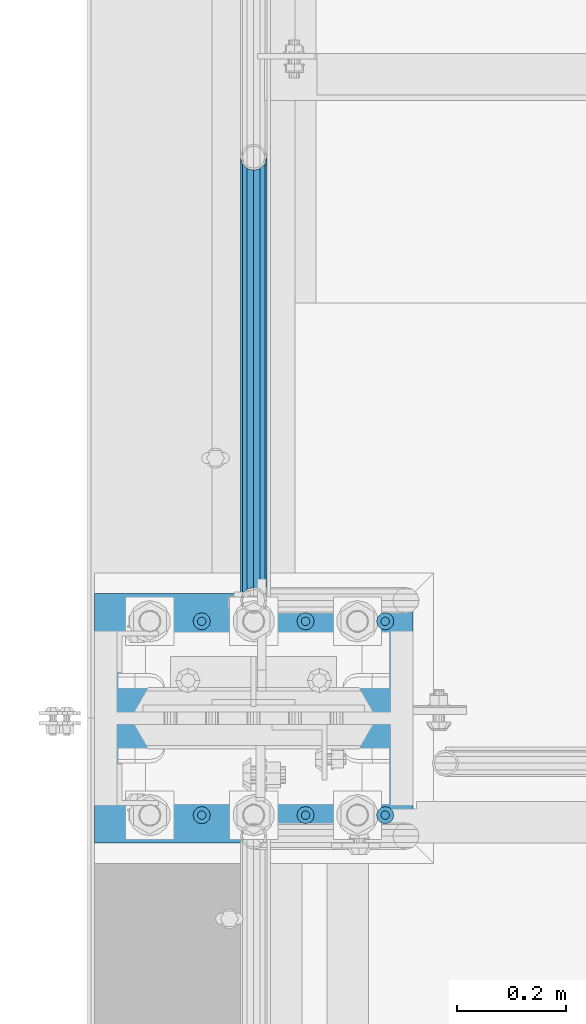
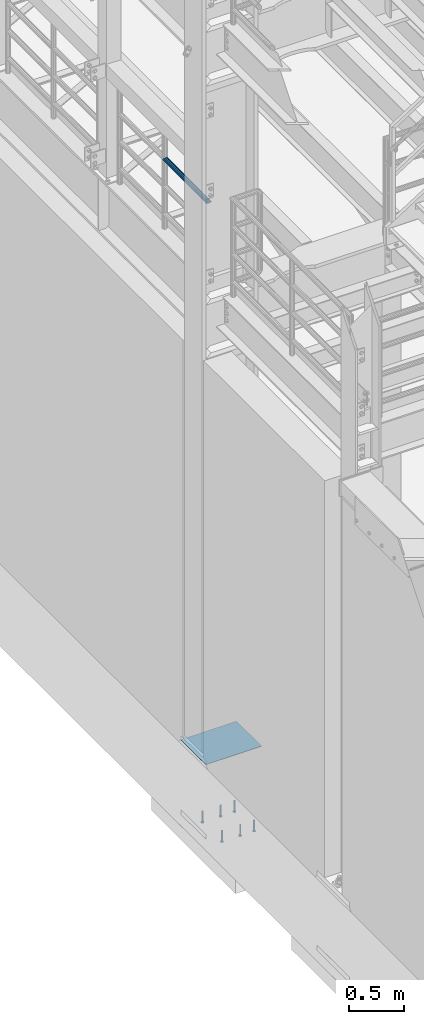
# One storey, part 1163 of 1876: 8 beams, 2 elements without a shape of their own.
"""IFC2X3 building model written with IfcOpenShell, lengths in millimetres."""

import ifcopenshell
import ifcopenshell.guid

model = None  # the IFC model being written
_history = None  # IfcOwnerHistory: only IFC2X3 demands one
_inside = {}  # id of a spatial element -> (the spatial element, [elements in it])
_under = {}  # id of a project, library or spatial element -> (it, [spatial elements below it])
_declared = {}  # id of a project -> (the project, [libraries it declares])
_typed = {}  # id of a type object -> (the type object, [elements of that type])
_made_of = {}  # id of a material, layer set ... -> (it, [elements and type objects made of it])


def new_model(schema):
    """Start an empty IFC model of exactly this schema.

    Asked for "IFC4X3", IfcOpenShell would pick the latest addendum, in which some entities
    have other attributes; the version numbers below select the first issue.
    IFC2X3 requires an IfcOwnerHistory on every rooted entity: one is made here for all.
    """
    global model, _history
    if schema == "IFC4X3":
        model = ifcopenshell.file(schema_version=(4, 3, 0, 0))
    else:
        model = ifcopenshell.file(schema=schema)
    _inside.clear()
    _under.clear()
    _declared.clear()
    _typed.clear()
    _made_of.clear()
    _history = None
    if model.schema == "IFC2X3":
        org = make("IfcOrganization", Name="unknown")
        user = make(
            "IfcPersonAndOrganization",
            ThePerson=make("IfcPerson", FamilyName="unknown"),
            TheOrganization=org,
        )
        app = make(
            "IfcApplication",
            ApplicationDeveloper=org,
            Version="unknown",
            ApplicationFullName="unknown",
            ApplicationIdentifier="unknown",
        )
        _history = make(
            "IfcOwnerHistory",
            OwningUser=user,
            OwningApplication=app,
            ChangeAction="ADDED",
            CreationDate=0,
        )
    return model


def make(cls, **values):
    """One entity of the class cls with the attributes given. An attribute that is None is left unset."""
    return model.create_entity(
        cls, **{name: value for name, value in values.items() if value is not None}
    )


def rooted(cls, **values):
    """An entity with a GlobalId (a new one), such as an element, a storey or a relation."""
    return make(cls, GlobalId=ifcopenshell.guid.new(), OwnerHistory=_history, **values)


def si_unit(unit_type, name, prefix=None):
    """IfcSIUnit, for example si_unit("LENGTHUNIT", "METRE", prefix="MILLI")."""
    return make("IfcSIUnit", UnitType=unit_type, Prefix=prefix, Name=name)


def assignment(units):
    """IfcUnitAssignment: the units of a project."""
    return None if units is None else make("IfcUnitAssignment", Units=units)


def point(xyz):
    """IfcCartesianPoint."""
    return None if xyz is None else make("IfcCartesianPoint", Coordinates=xyz)


def direction(xyz):
    """IfcDirection."""
    return None if xyz is None else make("IfcDirection", DirectionRatios=xyz)


def frame(location, z_axis=None, x_axis=None):
    """IfcAxis2Placement3D, a coordinate frame: its origin and axes. An axis left out is left unset."""
    return make(
        "IfcAxis2Placement3D",
        Location=point(location),
        Axis=direction(z_axis),
        RefDirection=direction(x_axis),
    )


def origin_with_axes():
    """The frame at (0, 0, 0) with the z axis (0, 0, 1) and the x axis (1, 0, 0) written out."""
    return frame((0.0, 0.0, 0.0), z_axis=(0.0, 0.0, 1.0), x_axis=(1.0, 0.0, 0.0))


def place(relative_to, where):
    """IfcLocalPlacement: puts the frame where relative to a parent placement (None: the world)."""
    return make(
        "IfcLocalPlacement", PlacementRelTo=relative_to, RelativePlacement=where
    )


def context(
    kind, dimensions, precision=None, world=None, true_north=None, identifier=None
):
    """IfcGeometricRepresentationContext, for example the 3D "Model" context."""
    return make(
        "IfcGeometricRepresentationContext",
        ContextIdentifier=identifier,
        ContextType=kind,
        CoordinateSpaceDimension=dimensions,
        Precision=precision,
        WorldCoordinateSystem=world,
        TrueNorth=true_north,
    )


def subcontext(parent, identifier, kind, view, scale=None):
    """IfcGeometricRepresentationSubContext, for example "Body" below "Model"."""
    return make(
        "IfcGeometricRepresentationSubContext",
        ContextIdentifier=identifier,
        ContextType=kind,
        ParentContext=parent,
        TargetScale=scale,
        TargetView=view,
    )


def project(units=None, contexts=None):
    """IfcProject with its units and contexts."""
    return rooted(
        "IfcProject",
        Name="project",
        RepresentationContexts=contexts,
        UnitsInContext=assignment(units),
    )


def spatial(cls, under=None, at=None, **own):
    """A site, building, storey or space (cls), placed at a placement, below another one or the project."""
    s = rooted(cls, ObjectPlacement=at, **own)
    if under is not None:
        _under.setdefault(under.id(), (under, []))[1].append(s)
    return s


def faces_of(points, faces, orient=None, outer=None):
    """IfcFace entities. A face is a list of loops; a loop is a list of indices into points, from 0.

    orient and outer hold one flag for each loop. By default every Orientation is true, the
    first loop of a face is its IfcFaceOuterBound and the others are IfcFaceBound.
    """
    made = []
    for i, loops in enumerate(faces):
        bounds = []
        for j, loop in enumerate(loops):
            is_outer = j == 0 if outer is None else outer[i][j]
            bounds.append(
                make(
                    "IfcFaceOuterBound" if is_outer else "IfcFaceBound",
                    Bound=make("IfcPolyLoop", Polygon=[points[k] for k in loop]),
                    Orientation=True if orient is None else orient[i][j],
                )
            )
        made.append(make("IfcFace", Bounds=bounds))
    return made


def faceted_brep(points, faces, orient=None, outer=None, voids=None):
    """IfcFacetedBrep: a solid bounded by flat faces; with voids (closed shells), ...WithVoids."""
    shared = [point(p) for p in points]
    hull = make("IfcClosedShell", CfsFaces=faces_of(shared, faces, orient, outer))
    if voids is None:
        return make("IfcFacetedBrep", Outer=hull)
    return make(
        "IfcFacetedBrepWithVoids",
        Outer=hull,
        Voids=[
            make(cls, CfsFaces=faces_of(shared, fs, o, b)) for cls, fs, o, b in voids
        ],
    )


def shape(context_of_items, identifier, shape_type, items):
    """IfcShapeRepresentation: the items that make up one representation, for example the "Body"."""
    return make(
        "IfcShapeRepresentation",
        ContextOfItems=context_of_items,
        RepresentationIdentifier=identifier,
        RepresentationType=shape_type,
        Items=items,
    )


def material(Name=None, Category=None):
    """IfcMaterial."""
    return make("IfcMaterial", Name=Name, Category=Category)


def made_of(thing, what):
    """Note that an element or type object is made of a material, layer set ...; save() writes the relation."""
    if what is not None:
        _made_of.setdefault(what.id(), (what, []))[1].append(thing)
    return thing


def type_object(cls, material=None, **own):
    """A type object (cls), such as IfcWallType, which elements share."""
    return made_of(rooted(cls, **own), material)


def element(
    cls,
    number,
    at=None,
    inside=None,
    cuts=None,
    type_object=None,
    material=None,
    context=None,
    identifier="Body",
    shape_type=None,
    held_by="IfcProductDefinitionShape",
    body=None,
    shapes=None,
    **own,
):
    """One element of the class cls, such as IfcWall. Its Tag is "e" and its number.

    at: its placement. inside: the storey or other place that contains it. cuts: it is an
    opening in that element (IfcRelVoidsElement). A single representation is given by context,
    identifier, shape_type and body (its items); several are given by shapes. held_by: the class
    of the entity that holds the representations. save() writes the other relations.
    """
    e = rooted(cls, Tag="e%d" % number, ObjectPlacement=at, **own)
    if body is not None:
        shapes = [shape(context, identifier, shape_type, body)]
    if shapes is not None:
        e.Representation = make(held_by, Representations=shapes)
    if inside is not None:
        _inside.setdefault(inside.id(), (inside, []))[1].append(e)
    if cuts is not None:
        rooted(
            "IfcRelVoidsElement", RelatingBuildingElement=cuts, RelatedOpeningElement=e
        )
    if type_object is not None:
        _typed.setdefault(type_object.id(), (type_object, []))[1].append(e)
    return made_of(e, material)


def aggregate(whole, parts):
    """IfcRelAggregates: a whole, such as a stair, and the parts it consists of."""
    return rooted("IfcRelAggregates", RelatingObject=whole, RelatedObjects=parts)


def save(model, path):
    """Write the relations noted so far, then the file.

    IfcRelAggregates (storeys below a building ...), IfcRelContainedInSpatialStructure (elements
    in a storey), IfcRelDefinesByType, IfcRelAssociatesMaterial and IfcRelDeclares: one each for
    every whole, place, type object, material and project.
    """
    for whole, parts in _under.values():
        aggregate(whole, parts)
    for where, things in _inside.values():
        rooted(
            "IfcRelContainedInSpatialStructure",
            RelatedElements=things,
            RelatingStructure=where,
        )
    for kind, things in _typed.values():
        rooted("IfcRelDefinesByType", RelatedObjects=things, RelatingType=kind)
    for what, things in _made_of.values():
        rooted("IfcRelAssociatesMaterial", RelatedObjects=things, RelatingMaterial=what)
    for by, libraries in _declared.values():
        rooted("IfcRelDeclares", RelatingContext=by, RelatedDefinitions=libraries)
    model.write(path)


model = new_model("IFC2X3")

# Units and contexts
model_context = context("Model", 3, precision=1e-05, world=origin_with_axes())
body_context = subcontext(model_context, "Body", "Model", "MODEL_VIEW")
ifc_project = project(units=[si_unit("LENGTHUNIT", "METRE", prefix="MILLI"), si_unit("AREAUNIT", "SQUARE_METRE"), si_unit("VOLUMEUNIT", "CUBIC_METRE"), si_unit("MASSUNIT", "GRAM", prefix="KILO"), si_unit("TIMEUNIT", "SECOND"), si_unit("PLANEANGLEUNIT", "RADIAN"), si_unit("SOLIDANGLEUNIT", "STERADIAN"), si_unit("THERMODYNAMICTEMPERATUREUNIT", "DEGREE_CELSIUS"), si_unit("LUMINOUSINTENSITYUNIT", "LUMEN")], contexts=[model_context])

# Site, building, storey
site_placement = place(None, origin_with_axes())
site = spatial("IfcSite", under=ifc_project, at=site_placement, CompositionType="ELEMENT")
building_placement = place(site_placement, origin_with_axes())
building = spatial("IfcBuilding", under=site, at=building_placement, Name="Undefined", CompositionType="ELEMENT")
storey_placement = place(building_placement, origin_with_axes())
storey = spatial("IfcBuildingStorey", under=building, at=storey_placement, Name="Undefined", CompositionType="ELEMENT", Elevation=0.0)

# Assembly, beam
assembly_1_placement = place(storey_placement, origin_with_axes())
assembly_1 = element("IfcElementAssembly", 1, at=assembly_1_placement, inside=storey, Name="RAIL", AssemblyPlace="NOTDEFINED", PredefinedType="RIGID_FRAME")
ifc_material_1 = material()
beam_type_1 = type_object("IfcBeamType", Name="PIPE1-1/2SCH40", PredefinedType="NOTDEFINED")
beam_1_placement = place(assembly_1_placement, frame((-1.00044417195022e-11, -4356.1, 5902.32500003594), z_axis=(0.0, 0.0, -1.0), x_axis=(0.0, 1.0, 0.0)))
beam_1 = element("IfcBeam", 2, at=beam_1_placement, type_object=beam_type_1, material=ifc_material_1, Name="RAIL", ObjectType="PIPE1-1/2SCH40", context=body_context, shape_type="Brep", body=[
    faceted_brep([(0.0, 24.1299999999992, 0.0), (12.0650000000064, 20.8971929933177, -12.0649999999987), (12.0650000000064, 20.8971929933177, 12.0649999999987), (12.0650000000064, -20.8971929933177, 12.0649999999987), (12.0650000000064, -20.8971929933177, -12.0649999999987), (0.0, -24.1299999999992, 0.0), (20.8971929933249, -12.0650000000005, 20.8971929933177), (20.8971929933249, -12.0650000000005, 15.8661214311796), (15.2545715621445, -17.7076214311801, 10.2235000000001), (12.5151929933249, -20.4470000000001, 0.0), (15.2545715621445, -17.7076214311801, -10.2235000000001), (20.8971929933249, -12.0650000000005, -15.8661214311796), (20.8971929933249, -12.0650000000005, -20.8971929933177), (24.1300000000063, 0.0, -20.4470000000001), (24.1300000000063, 0.0, -24.130000000001), (21.3906214311868, -10.2235000000001, -17.7076214311819), (21.3906214311868, 10.2235000000001, -17.7076214311819), (20.8971929933249, 12.0650000000005, -15.8661214311796), (20.8971929933249, 12.0650000000005, -20.8971929933177), (15.2545715621445, 17.7076214311801, -10.2235000000001), (12.5151929933249, 20.4470000000001, 0.0), (15.2545715621445, 17.7076214311801, 10.2235000000001), (20.8971929933249, 12.0650000000005, 15.8661214311796), (20.8971929933249, 12.0650000000005, 20.8971929933177), (21.3906214311868, 10.2235000000001, 17.7076214311819), (24.1300000000064, 0.0, 20.4470000000001), (24.1300000000064, 0.0, 24.130000000001), (21.3906214311868, -10.2235000000001, 17.7076214311819), (813.396900000002, 24.1300000000001, 0.0), (801.331900000001, 20.8971929933186, -12.0649999999987), (792.499707006684, 12.0649999999996, -20.8971929933177), (813.396900000002, -24.1300000000319, 0.0), (801.331900000001, -20.8971929933186, -12.0649999999987), (801.331900000001, -20.8971929933186, 12.0649999999987), (792.499707006684, -12.0649999999996, 20.8971929933177), (792.499707006684, -12.0649999999996, -20.8971929933177), (789.266900000001, 0.0, -24.130000000001), (792.00627856883, 10.2235000000001, -17.7076214311819), (789.266900000001, 0.0, -20.4470000000001), (792.499707006684, 12.0649999999678, -15.8661214312124), (792.499707006684, -12.0650000000314, -15.8661214311469), (792.006278568813, -10.2235000000001, -17.7076214311819), (798.142328437831, -17.7076214311801, -10.2235000000001), (800.881707006651, -20.4470000000001, 0.0), (798.142328437831, -17.7076214311801, 10.2235000000001), (792.499707006684, -12.0650000000314, 15.8661214311469), (792.006278568813, -10.2235000000001, 17.7076214311819), (789.266900000001, -9.09494701772928e-13, 20.4470000000001), (789.266900000001, -9.09494701772928e-13, 24.130000000001), (792.499707006684, 12.0649999999996, 20.8971929933177), (801.331900000001, 20.8971929933186, 12.0649999999987), (792.499707006684, 12.0649999999678, 15.8661214312124), (798.142328437896, 17.7076214311801, 10.2235000000001), (800.881707006714, 20.4470000000001, 0.0), (798.142328437896, 17.7076214311801, -10.2235000000001), (792.00627856883, 10.2235000000001, 17.7076214311819)], [[[0, 1, 2]], [[3, 4, 5]], [[6, 7, 8, 9, 10, 11, 12, 4, 3]], [[13, 14, 12, 11, 15]], [[16, 17, 18, 14, 13]], [[2, 1, 18, 17, 19, 20, 21, 22, 23]], [[23, 22, 24, 25, 26]], [[26, 25, 27, 7, 6]], [[1, 0, 28, 29]], [[18, 1, 29, 30]], [[31, 32, 33]], [[6, 3, 33, 34]], [[3, 5, 31, 33]], [[5, 4, 32, 31]], [[4, 12, 35, 32]], [[12, 14, 36, 35]], [[14, 18, 30, 36]], [[37, 38, 36, 30, 39]], [[40, 35, 36, 38, 41]], [[33, 32, 35, 40, 42, 43, 44, 45, 34]], [[34, 45, 46, 47, 48]], [[26, 6, 34, 48]], [[2, 23, 49, 50]], [[23, 26, 48, 49]], [[0, 2, 50, 28]], [[28, 50, 29]], [[49, 51, 52, 53, 54, 39, 30, 29, 50]], [[48, 47, 55, 51, 49]], [[25, 24, 55, 47]], [[55, 24, 22, 21, 52, 51]], [[21, 20, 53, 52]], [[20, 19, 54, 53]], [[19, 17, 16, 37, 39, 54]], [[16, 13, 38, 37]], [[13, 15, 41, 38]], [[41, 15, 11, 10, 42, 40]], [[10, 9, 43, 42]], [[9, 8, 44, 43]], [[8, 7, 27, 46, 45, 44]], [[27, 25, 47, 46]]]),
])
aggregate(assembly_1, [beam_1])

# Assembly, beams
assembly_2_placement = place(storey_placement, origin_with_axes())
assembly_2 = element("IfcElementAssembly", 3, at=assembly_2_placement, inside=storey, Name="TEMPLATE", AssemblyPlace="NOTDEFINED", PredefinedType="RIGID_FRAME")
ifc_material_2 = material(Name="STEEL/A36")
beam_type_2 = type_object("IfcBeamType", PredefinedType="NOTDEFINED")
beam_2_placement = place(assembly_2_placement, frame((292.1, -4572.0, 40.4814999999999), z_axis=(0.0, -1.0, 0.0), x_axis=(-1.0, 0.0, 0.0)))
beam_2 = element("IfcBeam", 4, at=beam_2_placement, type_object=beam_type_2, material=ifc_material_2, Name="TEMPLATE", context=body_context, shape_type="Brep", body=[
    faceted_brep([(9.09494701772928e-13, 2.3815, -228.600000000035), (-9.09494701772928e-13, 2.3815, 228.60000000004), (584.200000000001, 2.3815, 228.6), (584.200000000001, 2.3815, -228.6), (-9.09494701772928e-13, -2.3815, 228.60000000004), (584.200000000001, -2.3815, 228.6), (9.09494701772928e-13, -2.3815, -228.600000000035), (584.200000000001, -2.3815, -228.6)], [[[0, 1, 2, 3]], [[1, 4, 5, 2]], [[4, 6, 7, 5]], [[6, 0, 3, 7]], [[5, 7, 3, 2]], [[6, 4, 1, 0]]]),
])
ifc_material_3 = material(Name="STEEL/A108")
beam_type_3 = type_object("IfcBeamType", Name="5/8-DIA_HEADED ANCHOR STUD", PredefinedType="NOTDEFINED")
beam_3_placement = place(assembly_2_placement, frame((241.299998474243, -4749.8, -787.4), z_axis=(1.0, 0.0, 0.0), x_axis=(0.0, 0.0, -1.0)))
beam_3 = element("IfcBeam", 5, at=beam_3_placement, type_object=beam_type_3, material=ifc_material_3, Name="HEADED ANCHOR STUD", ObjectType="5/8-DIA_HEADED ANCHOR STUD", context=body_context, shape_type="Brep", body=[
    faceted_brep([(0.0, -7.94000005722046, 0.0), (0.0, -6.86999988555908, -3.97000002861023), (116.84, -6.86999988555908, -3.97000002861023), (116.84, -7.94000005722046, 0.0), (0.0, -3.97000002861023, -6.86999988555908), (116.84, -3.97000002861023, -6.86999988555908), (0.0, 0.0, -7.94000005722046), (116.84, 0.0, -7.94000005722046), (0.0, 3.97000002861023, -6.86999988555908), (116.84, 3.97000002861023, -6.86999988555908), (0.0, 6.86999988555908, -3.97000002861023), (116.84, 6.86999988555908, -3.97000002861023), (0.0, 7.94000005722046, 0.0), (116.84, 7.94000005722046, 0.0), (0.0, 6.86999988555908, 3.97000002861023), (116.84, 6.86999988555908, 3.97000002861023), (0.0, 3.97000002861023, 6.86999988555908), (116.84, 3.97000002861023, 6.86999988555908), (0.0, 0.0, 7.94000005722046), (116.84, 0.0, 7.94000005722046), (0.0, -3.97000002861023, 6.86999988555908), (116.84, -3.97000002861023, 6.86999988555908), (0.0, -6.86999988555908, 3.97000002861023), (116.84, -6.86999988555908, 3.97000002861023), (118.11, -13.75, -7.94000005722046), (118.11, -15.8800001144409, 0.0), (118.11, -7.94000005722046, -13.75), (118.11, 0.0, -15.8800001144409), (118.11, 7.94000005722046, -13.75), (118.11, 13.75, -7.94000005722046), (118.11, 15.8800001144409, 0.0), (118.11, 13.75, 7.94000005722046), (118.11, 7.94000005722046, 13.75), (118.11, 0.0, 15.8800001144409), (118.11, -7.94000005722046, 13.75), (118.11, -13.75, 7.94000005722046), (127.0, -13.75, -7.94000005722046), (127.0, -15.8800001144409, 0.0), (127.0, -7.94000005722046, -13.75), (127.0, 0.0, -15.8800001144409), (127.0, 7.94000005722046, -13.75), (127.0, 13.75, -7.94000005722046), (127.0, 15.8800001144409, 0.0), (127.0, 13.75, 7.94000005722046), (127.0, 7.94000005722046, 13.75), (127.0, 0.0, 15.8800001144409), (127.0, -7.94000005722046, 13.75), (127.0, -13.75, 7.94000005722046)], [[[0, 1, 2, 3]], [[1, 4, 5, 2]], [[4, 6, 7, 5]], [[6, 8, 9, 7]], [[8, 10, 11, 9]], [[10, 12, 13, 11]], [[12, 14, 15, 13]], [[14, 16, 17, 15]], [[16, 18, 19, 17]], [[18, 20, 21, 19]], [[20, 22, 23, 21]], [[22, 0, 3, 23]], [[22, 20, 18, 16, 14, 12, 10, 8, 6, 4, 1, 0]], [[3, 2, 24, 25]], [[2, 5, 26, 24]], [[5, 7, 27, 26]], [[7, 9, 28, 27]], [[9, 11, 29, 28]], [[11, 13, 30, 29]], [[13, 15, 31, 30]], [[15, 17, 32, 31]], [[17, 19, 33, 32]], [[19, 21, 34, 33]], [[21, 23, 35, 34]], [[23, 3, 25, 35]], [[25, 24, 36, 37]], [[24, 26, 38, 36]], [[26, 27, 39, 38]], [[27, 28, 40, 39]], [[28, 29, 41, 40]], [[29, 30, 42, 41]], [[30, 31, 43, 42]], [[31, 32, 44, 43]], [[32, 33, 45, 44]], [[33, 34, 46, 45]], [[34, 35, 47, 46]], [[35, 25, 37, 47]], [[38, 39, 40, 41, 42, 43, 44, 45, 46, 47, 37, 36]]]),
])
beam_4_placement = place(assembly_2_placement, frame((241.299998474243, -4394.2, -787.4), z_axis=(1.0, 0.0, 0.0), x_axis=(0.0, 0.0, -1.0)))
beam_4 = element("IfcBeam", 6, at=beam_4_placement, type_object=beam_type_3, material=ifc_material_3, Name="HEADED ANCHOR STUD", ObjectType="5/8-DIA_HEADED ANCHOR STUD", context=body_context, shape_type="Brep", body=[
    faceted_brep([(0.0, -7.94000005722046, 0.0), (0.0, -6.86999988555908, -3.97000002861023), (116.84, -6.86999988555908, -3.97000002861023), (116.84, -7.94000005722046, 0.0), (0.0, -3.97000002861023, -6.86999988555908), (116.84, -3.97000002861023, -6.86999988555908), (0.0, 0.0, -7.94000005722046), (116.84, 0.0, -7.94000005722046), (0.0, 3.97000002861023, -6.86999988555908), (116.84, 3.97000002861023, -6.86999988555908), (0.0, 6.86999988555908, -3.97000002861023), (116.84, 6.86999988555908, -3.97000002861023), (0.0, 7.94000005722046, 0.0), (116.84, 7.94000005722046, 0.0), (0.0, 6.86999988555908, 3.97000002861023), (116.84, 6.86999988555908, 3.97000002861023), (0.0, 3.97000002861023, 6.86999988555908), (116.84, 3.97000002861023, 6.86999988555908), (0.0, 0.0, 7.94000005722046), (116.84, 0.0, 7.94000005722046), (0.0, -3.97000002861023, 6.86999988555908), (116.84, -3.97000002861023, 6.86999988555908), (0.0, -6.86999988555908, 3.97000002861023), (116.84, -6.86999988555908, 3.97000002861023), (118.11, -13.75, -7.94000005722046), (118.11, -15.8800001144409, 0.0), (118.11, -7.94000005722046, -13.75), (118.11, 0.0, -15.8800001144409), (118.11, 7.94000005722046, -13.75), (118.11, 13.75, -7.94000005722046), (118.11, 15.8800001144409, 0.0), (118.11, 13.75, 7.94000005722046), (118.11, 7.94000005722046, 13.75), (118.11, 0.0, 15.8800001144409), (118.11, -7.94000005722046, 13.75), (118.11, -13.75, 7.94000005722046), (127.0, -13.75, -7.94000005722046), (127.0, -15.8800001144409, 0.0), (127.0, -7.94000005722046, -13.75), (127.0, 0.0, -15.8800001144409), (127.0, 7.94000005722046, -13.75), (127.0, 13.75, -7.94000005722046), (127.0, 15.8800001144409, 0.0), (127.0, 13.75, 7.94000005722046), (127.0, 7.94000005722046, 13.75), (127.0, 0.0, 15.8800001144409), (127.0, -7.94000005722046, 13.75), (127.0, -13.75, 7.94000005722046)], [[[0, 1, 2, 3]], [[1, 4, 5, 2]], [[4, 6, 7, 5]], [[6, 8, 9, 7]], [[8, 10, 11, 9]], [[10, 12, 13, 11]], [[12, 14, 15, 13]], [[14, 16, 17, 15]], [[16, 18, 19, 17]], [[18, 20, 21, 19]], [[20, 22, 23, 21]], [[22, 0, 3, 23]], [[22, 20, 18, 16, 14, 12, 10, 8, 6, 4, 1, 0]], [[3, 2, 24, 25]], [[2, 5, 26, 24]], [[5, 7, 27, 26]], [[7, 9, 28, 27]], [[9, 11, 29, 28]], [[11, 13, 30, 29]], [[13, 15, 31, 30]], [[15, 17, 32, 31]], [[17, 19, 33, 32]], [[19, 21, 34, 33]], [[21, 23, 35, 34]], [[23, 3, 25, 35]], [[25, 24, 36, 37]], [[24, 26, 38, 36]], [[26, 27, 39, 38]], [[27, 28, 40, 39]], [[28, 29, 41, 40]], [[29, 30, 42, 41]], [[30, 31, 43, 42]], [[31, 32, 44, 43]], [[32, 33, 45, 44]], [[33, 34, 46, 45]], [[34, 35, 47, 46]], [[35, 25, 37, 47]], [[38, 39, 40, 41, 42, 43, 44, 45, 46, 47, 37, 36]]]),
])
beam_5_placement = place(assembly_2_placement, frame((-95.2500000000003, -4749.8, -787.4), z_axis=(1.0, 0.0, 0.0), x_axis=(0.0, 0.0, -1.0)))
beam_5 = element("IfcBeam", 7, at=beam_5_placement, type_object=beam_type_3, material=ifc_material_3, Name="HEADED ANCHOR STUD", ObjectType="5/8-DIA_HEADED ANCHOR STUD", context=body_context, shape_type="Brep", body=[
    faceted_brep([(0.0, -7.94000005722046, 0.0), (0.0, -6.86999988555908, -3.97000002861023), (116.84, -6.86999988555908, -3.97000002861023), (116.84, -7.94000005722046, 0.0), (0.0, -3.97000002861023, -6.86999988555908), (116.84, -3.97000002861023, -6.86999988555908), (0.0, 0.0, -7.94000005722046), (116.84, 0.0, -7.94000005722046), (0.0, 3.97000002861023, -6.86999988555908), (116.84, 3.97000002861023, -6.86999988555908), (0.0, 6.86999988555908, -3.97000002861023), (116.84, 6.86999988555908, -3.97000002861023), (0.0, 7.94000005722046, 0.0), (116.84, 7.94000005722046, 0.0), (0.0, 6.86999988555908, 3.97000002861023), (116.84, 6.86999988555908, 3.97000002861023), (0.0, 3.97000002861023, 6.86999988555908), (116.84, 3.97000002861023, 6.86999988555908), (0.0, 0.0, 7.94000005722046), (116.84, 0.0, 7.94000005722046), (0.0, -3.97000002861023, 6.86999988555908), (116.84, -3.97000002861023, 6.86999988555908), (0.0, -6.86999988555908, 3.97000002861023), (116.84, -6.86999988555908, 3.97000002861023), (118.11, -13.75, -7.94000005722046), (118.11, -15.8800001144409, 0.0), (118.11, -7.94000005722046, -13.75), (118.11, 0.0, -15.8800001144409), (118.11, 7.94000005722046, -13.75), (118.11, 13.75, -7.94000005722046), (118.11, 15.8800001144409, 0.0), (118.11, 13.75, 7.94000005722046), (118.11, 7.94000005722046, 13.75), (118.11, 0.0, 15.8800001144409), (118.11, -7.94000005722046, 13.75), (118.11, -13.75, 7.94000005722046), (127.0, -13.75, -7.94000005722046), (127.0, -15.8800001144409, 0.0), (127.0, -7.94000005722046, -13.75), (127.0, 0.0, -15.8800001144409), (127.0, 7.94000005722046, -13.75), (127.0, 13.75, -7.94000005722046), (127.0, 15.8800001144409, 0.0), (127.0, 13.75, 7.94000005722046), (127.0, 7.94000005722046, 13.75), (127.0, 0.0, 15.8800001144409), (127.0, -7.94000005722046, 13.75), (127.0, -13.75, 7.94000005722046)], [[[0, 1, 2, 3]], [[1, 4, 5, 2]], [[4, 6, 7, 5]], [[6, 8, 9, 7]], [[8, 10, 11, 9]], [[10, 12, 13, 11]], [[12, 14, 15, 13]], [[14, 16, 17, 15]], [[16, 18, 19, 17]], [[18, 20, 21, 19]], [[20, 22, 23, 21]], [[22, 0, 3, 23]], [[22, 20, 18, 16, 14, 12, 10, 8, 6, 4, 1, 0]], [[3, 2, 24, 25]], [[2, 5, 26, 24]], [[5, 7, 27, 26]], [[7, 9, 28, 27]], [[9, 11, 29, 28]], [[11, 13, 30, 29]], [[13, 15, 31, 30]], [[15, 17, 32, 31]], [[17, 19, 33, 32]], [[19, 21, 34, 33]], [[21, 23, 35, 34]], [[23, 3, 25, 35]], [[25, 24, 36, 37]], [[24, 26, 38, 36]], [[26, 27, 39, 38]], [[27, 28, 40, 39]], [[28, 29, 41, 40]], [[29, 30, 42, 41]], [[30, 31, 43, 42]], [[31, 32, 44, 43]], [[32, 33, 45, 44]], [[33, 34, 46, 45]], [[34, 35, 47, 46]], [[35, 25, 37, 47]], [[38, 39, 40, 41, 42, 43, 44, 45, 46, 47, 37, 36]]]),
])
beam_6_placement = place(assembly_2_placement, frame((95.2500000000006, -4749.8, -787.4), z_axis=(1.0, 0.0, 0.0), x_axis=(0.0, 0.0, -1.0)))
beam_6 = element("IfcBeam", 8, at=beam_6_placement, type_object=beam_type_3, material=ifc_material_3, Name="HEADED ANCHOR STUD", ObjectType="5/8-DIA_HEADED ANCHOR STUD", context=body_context, shape_type="Brep", body=[
    faceted_brep([(0.0, -7.94000005722046, 0.0), (0.0, -6.86999988555908, -3.97000002861023), (116.84, -6.86999988555908, -3.97000002861023), (116.84, -7.94000005722046, 0.0), (0.0, -3.97000002861023, -6.86999988555908), (116.84, -3.97000002861023, -6.86999988555908), (0.0, 0.0, -7.94000005722046), (116.84, 0.0, -7.94000005722046), (0.0, 3.97000002861023, -6.86999988555908), (116.84, 3.97000002861023, -6.86999988555908), (0.0, 6.86999988555908, -3.97000002861023), (116.84, 6.86999988555908, -3.97000002861023), (0.0, 7.94000005722046, 0.0), (116.84, 7.94000005722046, 0.0), (0.0, 6.86999988555908, 3.97000002861023), (116.84, 6.86999988555908, 3.97000002861023), (0.0, 3.97000002861023, 6.86999988555908), (116.84, 3.97000002861023, 6.86999988555908), (0.0, 0.0, 7.94000005722046), (116.84, 0.0, 7.94000005722046), (0.0, -3.97000002861023, 6.86999988555908), (116.84, -3.97000002861023, 6.86999988555908), (0.0, -6.86999988555908, 3.97000002861023), (116.84, -6.86999988555908, 3.97000002861023), (118.11, -13.75, -7.94000005722046), (118.11, -15.8800001144409, 0.0), (118.11, -7.94000005722046, -13.75), (118.11, 0.0, -15.8800001144409), (118.11, 7.94000005722046, -13.75), (118.11, 13.75, -7.94000005722046), (118.11, 15.8800001144409, 0.0), (118.11, 13.75, 7.94000005722046), (118.11, 7.94000005722046, 13.75), (118.11, 0.0, 15.8800001144409), (118.11, -7.94000005722046, 13.75), (118.11, -13.75, 7.94000005722046), (127.0, -13.75, -7.94000005722046), (127.0, -15.8800001144409, 0.0), (127.0, -7.94000005722046, -13.75), (127.0, 0.0, -15.8800001144409), (127.0, 7.94000005722046, -13.75), (127.0, 13.75, -7.94000005722046), (127.0, 15.8800001144409, 0.0), (127.0, 13.75, 7.94000005722046), (127.0, 7.94000005722046, 13.75), (127.0, 0.0, 15.8800001144409), (127.0, -7.94000005722046, 13.75), (127.0, -13.75, 7.94000005722046)], [[[0, 1, 2, 3]], [[1, 4, 5, 2]], [[4, 6, 7, 5]], [[6, 8, 9, 7]], [[8, 10, 11, 9]], [[10, 12, 13, 11]], [[12, 14, 15, 13]], [[14, 16, 17, 15]], [[16, 18, 19, 17]], [[18, 20, 21, 19]], [[20, 22, 23, 21]], [[22, 0, 3, 23]], [[22, 20, 18, 16, 14, 12, 10, 8, 6, 4, 1, 0]], [[3, 2, 24, 25]], [[2, 5, 26, 24]], [[5, 7, 27, 26]], [[7, 9, 28, 27]], [[9, 11, 29, 28]], [[11, 13, 30, 29]], [[13, 15, 31, 30]], [[15, 17, 32, 31]], [[17, 19, 33, 32]], [[19, 21, 34, 33]], [[21, 23, 35, 34]], [[23, 3, 25, 35]], [[25, 24, 36, 37]], [[24, 26, 38, 36]], [[26, 27, 39, 38]], [[27, 28, 40, 39]], [[28, 29, 41, 40]], [[29, 30, 42, 41]], [[30, 31, 43, 42]], [[31, 32, 44, 43]], [[32, 33, 45, 44]], [[33, 34, 46, 45]], [[34, 35, 47, 46]], [[35, 25, 37, 47]], [[38, 39, 40, 41, 42, 43, 44, 45, 46, 47, 37, 36]]]),
])
beam_7_placement = place(assembly_2_placement, frame((-95.2500000000003, -4394.2, -787.4), z_axis=(1.0, 0.0, 0.0), x_axis=(0.0, 0.0, -1.0)))
beam_7 = element("IfcBeam", 9, at=beam_7_placement, type_object=beam_type_3, material=ifc_material_3, Name="HEADED ANCHOR STUD", ObjectType="5/8-DIA_HEADED ANCHOR STUD", context=body_context, shape_type="Brep", body=[
    faceted_brep([(0.0, -7.94000005722046, 0.0), (0.0, -6.86999988555908, -3.97000002861023), (116.84, -6.86999988555908, -3.97000002861023), (116.84, -7.94000005722046, 0.0), (0.0, -3.97000002861023, -6.86999988555908), (116.84, -3.97000002861023, -6.86999988555908), (0.0, 0.0, -7.94000005722046), (116.84, 0.0, -7.94000005722046), (0.0, 3.97000002861023, -6.86999988555908), (116.84, 3.97000002861023, -6.86999988555908), (0.0, 6.86999988555908, -3.97000002861023), (116.84, 6.86999988555908, -3.97000002861023), (0.0, 7.94000005722046, 0.0), (116.84, 7.94000005722046, 0.0), (0.0, 6.86999988555908, 3.97000002861023), (116.84, 6.86999988555908, 3.97000002861023), (0.0, 3.97000002861023, 6.86999988555908), (116.84, 3.97000002861023, 6.86999988555908), (0.0, 0.0, 7.94000005722046), (116.84, 0.0, 7.94000005722046), (0.0, -3.97000002861023, 6.86999988555908), (116.84, -3.97000002861023, 6.86999988555908), (0.0, -6.86999988555908, 3.97000002861023), (116.84, -6.86999988555908, 3.97000002861023), (118.11, -13.75, -7.94000005722046), (118.11, -15.8800001144409, 0.0), (118.11, -7.94000005722046, -13.75), (118.11, 0.0, -15.8800001144409), (118.11, 7.94000005722046, -13.75), (118.11, 13.75, -7.94000005722046), (118.11, 15.8800001144409, 0.0), (118.11, 13.75, 7.94000005722046), (118.11, 7.94000005722046, 13.75), (118.11, 0.0, 15.8800001144409), (118.11, -7.94000005722046, 13.75), (118.11, -13.75, 7.94000005722046), (127.0, -13.75, -7.94000005722046), (127.0, -15.8800001144409, 0.0), (127.0, -7.94000005722046, -13.75), (127.0, 0.0, -15.8800001144409), (127.0, 7.94000005722046, -13.75), (127.0, 13.75, -7.94000005722046), (127.0, 15.8800001144409, 0.0), (127.0, 13.75, 7.94000005722046), (127.0, 7.94000005722046, 13.75), (127.0, 0.0, 15.8800001144409), (127.0, -7.94000005722046, 13.75), (127.0, -13.75, 7.94000005722046)], [[[0, 1, 2, 3]], [[1, 4, 5, 2]], [[4, 6, 7, 5]], [[6, 8, 9, 7]], [[8, 10, 11, 9]], [[10, 12, 13, 11]], [[12, 14, 15, 13]], [[14, 16, 17, 15]], [[16, 18, 19, 17]], [[18, 20, 21, 19]], [[20, 22, 23, 21]], [[22, 0, 3, 23]], [[22, 20, 18, 16, 14, 12, 10, 8, 6, 4, 1, 0]], [[3, 2, 24, 25]], [[2, 5, 26, 24]], [[5, 7, 27, 26]], [[7, 9, 28, 27]], [[9, 11, 29, 28]], [[11, 13, 30, 29]], [[13, 15, 31, 30]], [[15, 17, 32, 31]], [[17, 19, 33, 32]], [[19, 21, 34, 33]], [[21, 23, 35, 34]], [[23, 3, 25, 35]], [[25, 24, 36, 37]], [[24, 26, 38, 36]], [[26, 27, 39, 38]], [[27, 28, 40, 39]], [[28, 29, 41, 40]], [[29, 30, 42, 41]], [[30, 31, 43, 42]], [[31, 32, 44, 43]], [[32, 33, 45, 44]], [[33, 34, 46, 45]], [[34, 35, 47, 46]], [[35, 25, 37, 47]], [[38, 39, 40, 41, 42, 43, 44, 45, 46, 47, 37, 36]]]),
])
beam_8_placement = place(assembly_2_placement, frame((95.2500000000006, -4394.2, -787.4), z_axis=(1.0, 0.0, 0.0), x_axis=(0.0, 0.0, -1.0)))
beam_8 = element("IfcBeam", 10, at=beam_8_placement, type_object=beam_type_3, material=ifc_material_3, Name="HEADED ANCHOR STUD", ObjectType="5/8-DIA_HEADED ANCHOR STUD", context=body_context, shape_type="Brep", body=[
    faceted_brep([(0.0, -7.94000005722046, 0.0), (0.0, -6.86999988555908, -3.97000002861023), (116.84, -6.86999988555908, -3.97000002861023), (116.84, -7.94000005722046, 0.0), (0.0, -3.97000002861023, -6.86999988555908), (116.84, -3.97000002861023, -6.86999988555908), (0.0, 0.0, -7.94000005722046), (116.84, 0.0, -7.94000005722046), (0.0, 3.97000002861023, -6.86999988555908), (116.84, 3.97000002861023, -6.86999988555908), (0.0, 6.86999988555908, -3.97000002861023), (116.84, 6.86999988555908, -3.97000002861023), (0.0, 7.94000005722046, 0.0), (116.84, 7.94000005722046, 0.0), (0.0, 6.86999988555908, 3.97000002861023), (116.84, 6.86999988555908, 3.97000002861023), (0.0, 3.97000002861023, 6.86999988555908), (116.84, 3.97000002861023, 6.86999988555908), (0.0, 0.0, 7.94000005722046), (116.84, 0.0, 7.94000005722046), (0.0, -3.97000002861023, 6.86999988555908), (116.84, -3.97000002861023, 6.86999988555908), (0.0, -6.86999988555908, 3.97000002861023), (116.84, -6.86999988555908, 3.97000002861023), (118.11, -13.75, -7.94000005722046), (118.11, -15.8800001144409, 0.0), (118.11, -7.94000005722046, -13.75), (118.11, 0.0, -15.8800001144409), (118.11, 7.94000005722046, -13.75), (118.11, 13.75, -7.94000005722046), (118.11, 15.8800001144409, 0.0), (118.11, 13.75, 7.94000005722046), (118.11, 7.94000005722046, 13.75), (118.11, 0.0, 15.8800001144409), (118.11, -7.94000005722046, 13.75), (118.11, -13.75, 7.94000005722046), (127.0, -13.75, -7.94000005722046), (127.0, -15.8800001144409, 0.0), (127.0, -7.94000005722046, -13.75), (127.0, 0.0, -15.8800001144409), (127.0, 7.94000005722046, -13.75), (127.0, 13.75, -7.94000005722046), (127.0, 15.8800001144409, 0.0), (127.0, 13.75, 7.94000005722046), (127.0, 7.94000005722046, 13.75), (127.0, 0.0, 15.8800001144409), (127.0, -7.94000005722046, 13.75), (127.0, -13.75, 7.94000005722046)], [[[0, 1, 2, 3]], [[1, 4, 5, 2]], [[4, 6, 7, 5]], [[6, 8, 9, 7]], [[8, 10, 11, 9]], [[10, 12, 13, 11]], [[12, 14, 15, 13]], [[14, 16, 17, 15]], [[16, 18, 19, 17]], [[18, 20, 21, 19]], [[20, 22, 23, 21]], [[22, 0, 3, 23]], [[22, 20, 18, 16, 14, 12, 10, 8, 6, 4, 1, 0]], [[3, 2, 24, 25]], [[2, 5, 26, 24]], [[5, 7, 27, 26]], [[7, 9, 28, 27]], [[9, 11, 29, 28]], [[11, 13, 30, 29]], [[13, 15, 31, 30]], [[15, 17, 32, 31]], [[17, 19, 33, 32]], [[19, 21, 34, 33]], [[21, 23, 35, 34]], [[23, 3, 25, 35]], [[25, 24, 36, 37]], [[24, 26, 38, 36]], [[26, 27, 39, 38]], [[27, 28, 40, 39]], [[28, 29, 41, 40]], [[29, 30, 42, 41]], [[30, 31, 43, 42]], [[31, 32, 44, 43]], [[32, 33, 45, 44]], [[33, 34, 46, 45]], [[34, 35, 47, 46]], [[35, 25, 37, 47]], [[38, 39, 40, 41, 42, 43, 44, 45, 46, 47, 37, 36]]]),
])
aggregate(assembly_2, [beam_3, beam_4, beam_5, beam_6, beam_7, beam_8, beam_2])

save(model, "model.ifc")
